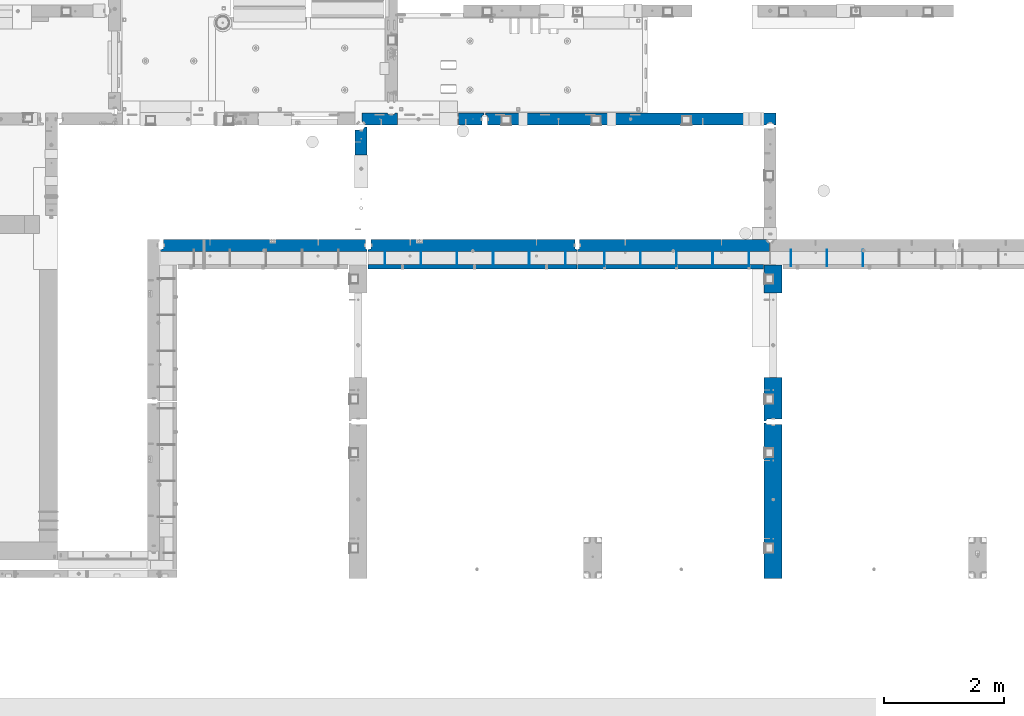
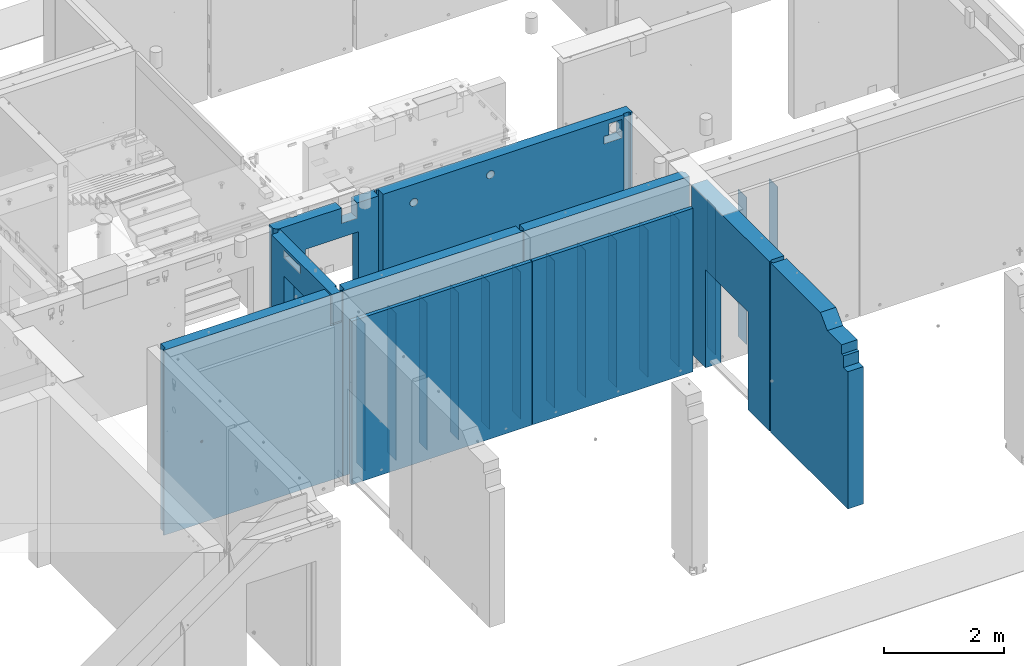
# One storey, part 172 of 264: 24 walls, 9 elements without a shape of their own.
"""IFC2X3 building model written with IfcOpenShell, lengths in millimetres."""

from ifc_helpers import new_model, si_unit, frame, origin_with_axes, place, context, subcontext, project, spatial, faceted_brep, material, type_object, element, aggregate, save


model = new_model("IFC2X3")

# Units and contexts
model_context = context("Model", 3, precision=1e-05, world=origin_with_axes())
body_context = subcontext(model_context, "Body", "Model", "MODEL_VIEW")
ifc_project = project(units=[si_unit("LENGTHUNIT", "METRE", prefix="MILLI"), si_unit("AREAUNIT", "SQUARE_METRE"), si_unit("VOLUMEUNIT", "CUBIC_METRE"), si_unit("MASSUNIT", "GRAM", prefix="KILO"), si_unit("TIMEUNIT", "SECOND"), si_unit("PLANEANGLEUNIT", "RADIAN"), si_unit("SOLIDANGLEUNIT", "STERADIAN"), si_unit("THERMODYNAMICTEMPERATUREUNIT", "DEGREE_CELSIUS"), si_unit("LUMINOUSINTENSITYUNIT", "LUMEN")], contexts=[model_context])

# Site, building, storey
site_placement = place(None, origin_with_axes())
site = spatial("IfcSite", under=ifc_project, at=site_placement, CompositionType="ELEMENT")
building_placement = place(site_placement, origin_with_axes())
building = spatial("IfcBuilding", under=site, at=building_placement, CompositionType="ELEMENT")
storey_placement = place(building_placement, origin_with_axes())
storey = spatial("IfcBuildingStorey", under=building, at=storey_placement, Name="K", CompositionType="ELEMENT", Elevation=0.0)

# Assembly, walls
assembly_1_placement = place(storey_placement, origin_with_axes())
assembly_1 = element("IfcElementAssembly", 1, at=assembly_1_placement, inside=storey, AssemblyPlace="NOTDEFINED", PredefinedType="REINFORCEMENT_UNIT")
ifc_material_1 = material(Name="Undefined")
wall_type_1 = type_object("IfcWallType", PredefinedType="NOTDEFINED")
wall_1_placement = place(assembly_1_placement, frame((25204.9962229193, 12730.0010506694, 79360.0), z_axis=(0.0, 0.0, 1.0), x_axis=(0.0, 1.0, 0.0)))
wall_1 = element("IfcWall", 2, at=wall_1_placement, type_object=wall_type_1, material=ifc_material_1, Name="(PD)", context=body_context, shape_type="Brep", body=[
    faceted_brep([(0.0, 4.99999999999909, -1500.0), (0.0, 4.99999999999909, 1500.0), (280.000000000024, 5.0, 1500.0), (280.000000000024, 5.0, -1500.0), (0.0, -5.00000000000091, 1500.0), (280.000000000025, -5.0, 1500.0), (0.0, -5.00000000000091, -1500.0), (280.000000000025, -5.0, -1500.0)], [[[0, 1, 2, 3]], [[1, 4, 5, 2]], [[4, 6, 7, 5]], [[6, 0, 3, 7]], [[5, 7, 3, 2]], [[6, 4, 1, 0]]]),
])
wall_2_placement = place(assembly_1_placement, frame((24604.9962229193, 12730.0010506694, 79360.0), z_axis=(0.0, 0.0, 1.0), x_axis=(0.0, 1.0, 0.0)))
wall_2 = element("IfcWall", 3, at=wall_2_placement, type_object=wall_type_1, material=ifc_material_1, Name="(PD)", context=body_context, shape_type="Brep", body=[
    faceted_brep([(0.0, 4.99999999999909, -1500.0), (0.0, 4.99999999999909, 1500.0), (280.000000000024, 5.0, 1500.0), (280.000000000024, 5.0, -1500.0), (0.0, -5.00000000000091, 1500.0), (280.000000000025, -5.0, 1500.0), (0.0, -5.00000000000091, -1500.0), (280.000000000025, -5.0, -1500.0)], [[[0, 1, 2, 3]], [[1, 4, 5, 2]], [[4, 6, 7, 5]], [[6, 0, 3, 7]], [[5, 7, 3, 2]], [[6, 4, 1, 0]]]),
])
wall_3_placement = place(assembly_1_placement, frame((24004.9962229193, 12730.0010506694, 79360.0), z_axis=(0.0, 0.0, 1.0), x_axis=(0.0, 1.0, 0.0)))
wall_3 = element("IfcWall", 4, at=wall_3_placement, type_object=wall_type_1, material=ifc_material_1, Name="(PD)", context=body_context, shape_type="Brep", body=[
    faceted_brep([(0.0, 4.99999999999909, -1500.0), (0.0, 4.99999999999909, 1500.0), (280.000000000024, 5.0, 1500.0), (280.000000000024, 5.0, -1500.0), (0.0, -5.00000000000091, 1500.0), (280.000000000025, -5.0, 1500.0), (0.0, -5.00000000000091, -1500.0), (280.000000000025, -5.0, -1500.0)], [[[0, 1, 2, 3]], [[1, 4, 5, 2]], [[4, 6, 7, 5]], [[6, 0, 3, 7]], [[5, 7, 3, 2]], [[6, 4, 1, 0]]]),
])
wall_4_placement = place(assembly_1_placement, frame((23404.9962229193, 12730.0010506694, 79360.0), z_axis=(0.0, 0.0, 1.0), x_axis=(0.0, 1.0, 0.0)))
wall_4 = element("IfcWall", 5, at=wall_4_placement, type_object=wall_type_1, material=ifc_material_1, Name="(PD)", context=body_context, shape_type="Brep", body=[
    faceted_brep([(0.0, 4.99999999999909, -1500.0), (0.0, 4.99999999999909, 1500.0), (280.000000000024, 5.0, 1500.0), (280.000000000024, 5.0, -1500.0), (0.0, -5.00000000000091, 1500.0), (280.000000000025, -5.0, 1500.0), (0.0, -5.00000000000091, -1500.0), (280.000000000025, -5.0, -1500.0)], [[[0, 1, 2, 3]], [[1, 4, 5, 2]], [[4, 6, 7, 5]], [[6, 0, 3, 7]], [[5, 7, 3, 2]], [[6, 4, 1, 0]]]),
])
wall_5_placement = place(assembly_1_placement, frame((22804.9962229193, 12730.0010506694, 79360.0), z_axis=(0.0, 0.0, 1.0), x_axis=(0.0, 1.0, 0.0)))
wall_5 = element("IfcWall", 6, at=wall_5_placement, type_object=wall_type_1, material=ifc_material_1, Name="(PD)", context=body_context, shape_type="Brep", body=[
    faceted_brep([(0.0, 4.99999999999909, -1500.0), (0.0, 4.99999999999909, 1500.0), (280.000000000024, 5.0, 1500.0), (280.000000000024, 5.0, -1500.0), (0.0, -5.00000000000091, 1500.0), (280.000000000025, -5.0, 1500.0), (0.0, -5.00000000000091, -1500.0), (280.000000000025, -5.0, -1500.0)], [[[0, 1, 2, 3]], [[1, 4, 5, 2]], [[4, 6, 7, 5]], [[6, 0, 3, 7]], [[5, 7, 3, 2]], [[6, 4, 1, 0]]]),
])

# Assembly, wall
assembly_2_placement = place(storey_placement, origin_with_axes())
assembly_2 = element("IfcElementAssembly", 7, at=assembly_2_placement, inside=storey, AssemblyPlace="NOTDEFINED", PredefinedType="REINFORCEMENT_UNIT")
wall_6_placement = place(assembly_2_placement, frame((28254.9962229193, 12730.0010506694, 79360.0), z_axis=(0.0, 0.0, 1.0), x_axis=(0.0, 1.0, 0.0)))
wall_6 = element("IfcWall", 8, at=wall_6_placement, type_object=wall_type_1, material=ifc_material_1, Name="(PD)", context=body_context, shape_type="Brep", body=[
    faceted_brep([(0.0, 4.99999999999909, -1500.0), (0.0, 4.99999999999909, 1500.0), (280.000000000024, 5.0, 1500.0), (280.000000000024, 5.0, -1500.0), (0.0, -5.00000000000091, 1500.0), (280.000000000025, -5.0, 1500.0), (0.0, -5.00000000000091, -1500.0), (280.000000000025, -5.0, -1500.0)], [[[0, 1, 2, 3]], [[1, 4, 5, 2]], [[4, 6, 7, 5]], [[6, 0, 3, 7]], [[5, 7, 3, 2]], [[6, 4, 1, 0]]]),
])

# Wall
wall_7_placement = place(assembly_1_placement, frame((22204.9962229193, 12730.0010506694, 79360.0), z_axis=(0.0, 0.0, 1.0), x_axis=(0.0, 1.0, 0.0)))
wall_7 = element("IfcWall", 9, at=wall_7_placement, type_object=wall_type_1, material=ifc_material_1, Name="(PD)", context=body_context, shape_type="Brep", body=[
    faceted_brep([(0.0, 4.99999999999909, -1500.0), (0.0, 4.99999999999909, 1500.0), (280.000000000024, 5.0, 1500.0), (280.000000000024, 5.0, -1500.0), (0.0, -5.00000000000091, 1500.0), (280.000000000025, -5.0, 1500.0), (0.0, -5.00000000000091, -1500.0), (280.000000000025, -5.0, -1500.0)], [[[0, 1, 2, 3]], [[1, 4, 5, 2]], [[4, 6, 7, 5]], [[6, 0, 3, 7]], [[5, 7, 3, 2]], [[6, 4, 1, 0]]]),
])

wall_8_placement = place(assembly_2_placement, frame((25854.9962229193, 12730.0010506694, 79360.0), z_axis=(0.0, 0.0, 1.0), x_axis=(0.0, 1.0, 0.0)))
wall_8 = element("IfcWall", 10, at=wall_8_placement, type_object=wall_type_1, material=ifc_material_1, Name="(PD)", context=body_context, shape_type="Brep", body=[
    faceted_brep([(0.0, 4.99999999999909, -1500.0), (0.0, 4.99999999999909, 1500.0), (280.000000000024, 5.0, 1500.0), (280.000000000024, 5.0, -1500.0), (0.0, -5.00000000000091, 1500.0), (280.000000000025, -5.0, 1500.0), (0.0, -5.00000000000091, -1500.0), (280.000000000025, -5.0, -1500.0)], [[[0, 1, 2, 3]], [[1, 4, 5, 2]], [[4, 6, 7, 5]], [[6, 0, 3, 7]], [[5, 7, 3, 2]], [[6, 4, 1, 0]]]),
])

wall_9_placement = place(assembly_2_placement, frame((26454.9962229193, 12730.0010506694, 79360.0), z_axis=(0.0, 0.0, 1.0), x_axis=(0.0, 1.0, 0.0)))
wall_9 = element("IfcWall", 11, at=wall_9_placement, type_object=wall_type_1, material=ifc_material_1, Name="(PD)", context=body_context, shape_type="Brep", body=[
    faceted_brep([(0.0, 4.99999999999909, -1500.0), (0.0, 4.99999999999909, 1500.0), (280.000000000024, 5.0, 1500.0), (280.000000000024, 5.0, -1500.0), (0.0, -5.00000000000091, 1500.0), (280.000000000025, -5.0, 1500.0), (0.0, -5.00000000000091, -1500.0), (280.000000000025, -5.0, -1500.0)], [[[0, 1, 2, 3]], [[1, 4, 5, 2]], [[4, 6, 7, 5]], [[6, 0, 3, 7]], [[5, 7, 3, 2]], [[6, 4, 1, 0]]]),
])

wall_10_placement = place(assembly_2_placement, frame((27054.9962229193, 12730.0010506694, 79360.0), z_axis=(0.0, 0.0, 1.0), x_axis=(0.0, 1.0, 0.0)))
wall_10 = element("IfcWall", 12, at=wall_10_placement, type_object=wall_type_1, material=ifc_material_1, Name="(PD)", context=body_context, shape_type="Brep", body=[
    faceted_brep([(0.0, 4.99999999999909, -1500.0), (0.0, 4.99999999999909, 1500.0), (280.000000000024, 5.0, 1500.0), (280.000000000024, 5.0, -1500.0), (0.0, -5.00000000000091, 1500.0), (280.000000000025, -5.0, 1500.0), (0.0, -5.00000000000091, -1500.0), (280.000000000025, -5.0, -1500.0)], [[[0, 1, 2, 3]], [[1, 4, 5, 2]], [[4, 6, 7, 5]], [[6, 0, 3, 7]], [[5, 7, 3, 2]], [[6, 4, 1, 0]]]),
])

wall_11_placement = place(assembly_2_placement, frame((27654.9962229193, 12730.0010506694, 79360.0), z_axis=(0.0, 0.0, 1.0), x_axis=(0.0, 1.0, 0.0)))
wall_11 = element("IfcWall", 13, at=wall_11_placement, type_object=wall_type_1, material=ifc_material_1, Name="(PD)", context=body_context, shape_type="Brep", body=[
    faceted_brep([(0.0, 4.99999999999909, -1500.0), (0.0, 4.99999999999909, 1500.0), (280.000000000024, 5.0, 1500.0), (280.000000000024, 5.0, -1500.0), (0.0, -5.00000000000091, 1500.0), (280.000000000025, -5.0, 1500.0), (0.0, -5.00000000000091, -1500.0), (280.000000000025, -5.0, -1500.0)], [[[0, 1, 2, 3]], [[1, 4, 5, 2]], [[4, 6, 7, 5]], [[6, 0, 3, 7]], [[5, 7, 3, 2]], [[6, 4, 1, 0]]]),
])

# Assembly, walls
assembly_3_placement = place(storey_placement, origin_with_axes())
assembly_3 = element("IfcElementAssembly", 14, at=assembly_3_placement, inside=storey, AssemblyPlace="NOTDEFINED", PredefinedType="REINFORCEMENT_UNIT")
wall_12_placement = place(assembly_3_placement, frame((28955.0062229193, 12730.0010506694, 79360.0), z_axis=(0.0, 0.0, 1.0), x_axis=(0.0, 1.0, 0.0)))
wall_12 = element("IfcWall", 15, at=wall_12_placement, type_object=wall_type_1, material=ifc_material_1, Name="(PD)", context=body_context, shape_type="Brep", body=[
    faceted_brep([(0.0, 4.99999999999909, -1500.0), (0.0, 4.99999999999909, 1500.0), (280.000000000024, 5.0, 1500.0), (280.000000000024, 5.0, -1500.0), (0.0, -5.00000000000091, 1500.0), (280.000000000025, -5.0, 1500.0), (0.0, -5.00000000000091, -1500.0), (280.000000000025, -5.0, -1500.0)], [[[0, 1, 2, 3]], [[1, 4, 5, 2]], [[4, 6, 7, 5]], [[6, 0, 3, 7]], [[5, 7, 3, 2]], [[6, 4, 1, 0]]]),
])
wall_13_placement = place(assembly_3_placement, frame((29555.0062229193, 12730.0010506694, 79360.0), z_axis=(0.0, 0.0, 1.0), x_axis=(0.0, 1.0, 0.0)))
wall_13 = element("IfcWall", 16, at=wall_13_placement, type_object=wall_type_1, material=ifc_material_1, Name="(PD)", context=body_context, shape_type="Brep", body=[
    faceted_brep([(0.0, 4.99999999999909, -1500.0), (0.0, 4.99999999999909, 1500.0), (280.000000000024, 5.0, 1500.0), (280.000000000024, 5.0, -1500.0), (0.0, -5.00000000000091, 1500.0), (280.000000000025, -5.0, 1500.0), (0.0, -5.00000000000091, -1500.0), (280.000000000025, -5.0, -1500.0)], [[[0, 1, 2, 3]], [[1, 4, 5, 2]], [[4, 6, 7, 5]], [[6, 0, 3, 7]], [[5, 7, 3, 2]], [[6, 4, 1, 0]]]),
])
wall_14_placement = place(assembly_3_placement, frame((30155.0062229193, 12730.0010506694, 79360.0), z_axis=(0.0, 0.0, 1.0), x_axis=(0.0, 1.0, 0.0)))
wall_14 = element("IfcWall", 17, at=wall_14_placement, type_object=wall_type_1, material=ifc_material_1, Name="(PD)", context=body_context, shape_type="Brep", body=[
    faceted_brep([(0.0, 4.99999999999909, -1500.0), (0.0, 4.99999999999909, 1500.0), (280.000000000024, 5.0, 1500.0), (280.000000000024, 5.0, -1500.0), (0.0, -5.00000000000091, 1500.0), (280.000000000025, -5.0, 1500.0), (0.0, -5.00000000000091, -1500.0), (280.000000000025, -5.0, -1500.0)], [[[0, 1, 2, 3]], [[1, 4, 5, 2]], [[4, 6, 7, 5]], [[6, 0, 3, 7]], [[5, 7, 3, 2]], [[6, 4, 1, 0]]]),
])
aggregate(assembly_3, [wall_12, wall_13, wall_14])

# Assembly, wall
assembly_4_placement = place(storey_placement, origin_with_axes())
assembly_4 = element("IfcElementAssembly", 18, at=assembly_4_placement, inside=storey, AssemblyPlace="NOTDEFINED", PredefinedType="REINFORCEMENT_UNIT")
ifc_material_2 = material(Name="CONCRETE/C30/37")
wall_type_2 = type_object("IfcWallType", PredefinedType="NOTDEFINED")
wall_15_placement = place(assembly_4_placement, frame((28660.0, 10145.0, 79745.0), z_axis=(0.0, 0.0, 1.0), x_axis=(0.0, 1.0, 0.0)))
wall_15 = element("IfcWall", 19, at=wall_15_placement, type_object=wall_type_2, material=ifc_material_2, context=body_context, shape_type="Brep", body=[
    faceted_brep([(15.0, 120.0, 1725.0), (15.0, 120.0, -1725.0), (45.0, 107.0, -1725.0), (45.0, 107.0, 1725.0), (45.0, -150.0, 1725.0), (45.0, -150.0, -1725.0), (734.999769628048, -150.0, -1725.0), (734.999769628048, 150.0, -1725.0), (734.999769628048, 150.000154078007, 270.0), (734.999769628048, -150.0, 270.0), (2610.0, 150.0, -1725.0), (2610.0, -150.0, -1725.0), (2145.00189658492, -150.0, -1725.0), (2145.00189658492, 150.0, -1725.0), (2145.00189658492, -150.0, 270.0), (2145.00189658492, 150.000154078007, 270.0), (15.0, 150.0, -1725.0), (15.0, 150.0, 1725.0), (2610.0, 150.0, 1725.0), (2610.0, -150.0, 1725.0)], [[[0, 1, 2, 3]], [[4, 3, 2, 5]], [[6, 7, 8, 9]], [[10, 11, 12, 13]], [[14, 15, 13, 12]], [[9, 8, 15, 14]], [[7, 16, 17, 18, 10, 13, 15, 8]], [[19, 11, 10, 18]], [[6, 9, 14, 12, 11, 19, 4, 5]], [[1, 16, 7, 6, 5, 2]], [[17, 16, 1, 0]], [[19, 18, 17, 0, 3, 4]]]),
])
aggregate(assembly_4, [wall_15])

assembly_5_placement = place(storey_placement, origin_with_axes())
assembly_5 = element("IfcElementAssembly", 20, at=assembly_5_placement, inside=storey, AssemblyPlace="NOTDEFINED", PredefinedType="REINFORCEMENT_UNIT")
wall_16_placement = place(assembly_5_placement, frame((28660.0, 7545.0, 79745.0), z_axis=(0.0, 0.0, 1.0), x_axis=(0.0, 1.0, 0.0)))
wall_16 = element("IfcWall", 21, at=wall_16_placement, type_object=wall_type_2, material=ifc_material_2, context=body_context, shape_type="Brep", body=[
    faceted_brep([(145.0, -150.0, 1070.0), (145.0, 150.0, 1070.0), (0.0, 150.0, 1070.0), (0.0, -150.0, 1070.0), (145.0, -150.0, 1305.0), (145.0, 150.0, 1305.0), (0.0, -150.0, -1725.0), (0.0, 150.0, -1725.0), (2585.0, 150.0, -1725.0), (2585.0, 119.999999999996, -1725.0), (2555.0, 107.0, -1725.0), (2555.0, -150.0, -1725.0), (2585.0, 150.0, 1725.0), (2585.0, 119.999999999996, 1725.0), (2555.0, 107.0, 1725.0), (2555.0, -150.0, 1725.0), (914.999832520542, 150.0, 1725.0), (914.999832520542, -150.0, 1725.0), (684.999832520542, 150.0, 1495.0), (684.999832520542, -150.0, 1495.0), (205.0, 150.0, 1495.0), (205.0, -150.0, 1495.0), (205.0, 150.0, 1305.0), (205.0, -150.0, 1305.0)], [[[0, 1, 2, 3]], [[4, 5, 1, 0]], [[6, 7, 8, 9, 10, 11]], [[8, 12, 13, 9]], [[14, 10, 9, 13]], [[15, 11, 10, 14]], [[13, 12, 16, 17, 15, 14]], [[17, 16, 18, 19]], [[19, 18, 20, 21]], [[21, 20, 22, 23]], [[3, 6, 11, 15, 17, 19, 21, 23, 4, 0]], [[7, 6, 3, 2]], [[22, 20, 18, 16, 12, 8, 7, 2, 1, 5]], [[23, 22, 5, 4]]]),
])
aggregate(assembly_5, [wall_16])

# Wall
wall_type_3 = type_object("IfcWallType", PredefinedType="NOTDEFINED")
wall_17_placement = place(assembly_1_placement, frame((25395.0012286569, 12725.0018965848, 79365.0), z_axis=(0.0, 0.0, 1.0), x_axis=(-1.0, 3.00000001838171e-08, 0.0)))
wall_17 = element("IfcWall", 22, at=wall_17_placement, type_object=wall_type_3, material=ifc_material_2, context=body_context, shape_type="Brep", body=[
    faceted_brep([(0.0, 35.0, -1665.0), (0.0, 35.0, 1665.0), (3470.00122865687, 35.0, 1665.0), (3470.00122865687, 35.0, -1665.0), (0.0, -35.0, 1665.0), (3470.00122865687, -35.0, 1665.0), (0.0, -35.0, -1665.0), (3470.00122865687, -35.0, -1665.0)], [[[0, 1, 2, 3]], [[1, 4, 5, 2]], [[4, 6, 7, 5]], [[6, 0, 3, 7]], [[5, 7, 3, 2]], [[6, 4, 1, 0]]]),
])

wall_18_placement = place(assembly_2_placement, frame((28495.0, 12725.0018965848, 79365.0), z_axis=(0.0, 0.0, 1.0), x_axis=(-1.0, 3.00000001838171e-08, 0.0)))
wall_18 = element("IfcWall", 23, at=wall_18_placement, type_object=wall_type_3, material=ifc_material_2, context=body_context, shape_type="Brep", body=[
    faceted_brep([(0.0, 35.0, -1665.0), (0.0, 35.0, 1665.0), (3085.0, 35.0, 1665.0), (3085.0, 35.0, -1665.0), (0.0, -35.0, 1665.0), (3085.0, -35.0, 1665.0), (0.0, -35.0, -1665.0), (3085.0, -35.0, -1665.0)], [[[0, 1, 2, 3]], [[1, 4, 5, 2]], [[4, 6, 7, 5]], [[6, 0, 3, 7]], [[5, 7, 3, 2]], [[6, 4, 1, 0]]]),
])

# Assembly, wall
assembly_6_placement = place(storey_placement, origin_with_axes())
assembly_6 = element("IfcElementAssembly", 24, at=assembly_6_placement, inside=storey, AssemblyPlace="NOTDEFINED", PredefinedType="REINFORCEMENT_UNIT")
ifc_material_3 = material(Name="CONCRETE/C25/30")
wall_type_4 = type_object("IfcWallType", PredefinedType="NOTDEFINED")
wall_19_placement = place(assembly_6_placement, frame((21810.0002919986, 15180.0, 80122.5), z_axis=(0.0, 0.0, 1.0), x_axis=(1.0, 0.0, 0.0)))
wall_19 = element("IfcWall", 25, at=wall_19_placement, type_object=wall_type_4, material=ifc_material_3, context=body_context, shape_type="Brep", body=[
    faceted_brep([(1599.9997446583, 100.0, 1347.5), (1599.9997446583, 99.9999999999964, 1337.5), (1599.9997446583, -99.9999999999982, 1337.5), (1599.9997446583, -100.0, 1347.5), (1299.9997446583, 100.0, 1347.5), (1299.9997446583, -100.0, 1347.5), (1299.9997446583, -99.9999999999982, 1337.5), (1299.9997446583, 99.9999999999964, 1337.5), (2039.99985400072, 100.0, -1347.5), (2039.99985400072, 100.0, 1347.5), (2039.99985400072, 70.0, 1347.5), (2039.99985400072, 70.0, -1347.5), (2009.99985400072, -100.0, 1347.5), (2009.99985400072, 57.0, 1347.5), (2009.99985400072, -100.0, -1347.5), (2009.99985400072, 57.0, -1347.5), (1619.99614120679, -100.0, -1347.5), (1619.99667220679, 100.0, -1347.5), (1619.99614120679, -100.0, 752.5), (1619.99667220678, 100.0, 752.5), (599.99917704994, -100.0, 752.5), (599.999708049942, 100.0, 752.5), (599.99917704994, -100.0, -1347.5), (599.999708049942, 100.0, -1347.5), (74.9997080014437, -100.0, -1347.5), (14.9997080014437, -40.0, -1347.5), (14.9997080014437, 100.0, -1347.5), (434.999708001444, 100.0, -1347.5), (447.999708001444, 80.0, -1347.5), (551.999708001444, 80.0, -1347.5), (564.999708001447, 100.0, -1347.5), (74.9997080014437, -100.0, 1347.5), (14.9997080014437, -40.0, 1347.5), (14.9997080014437, 100.0, 1347.5), (434.999708001444, 100.0, 1347.5), (447.999708001444, 80.0, 1347.5), (551.999708001444, 80.0, 1347.5), (564.999708001444, 100.0, 1347.5), (1299.9997446583, -99.9999999999982, 1037.5), (1299.9997446583, 99.9999999999964, 1037.5), (1599.9997446583, -99.9999999999982, 1037.5), (1599.9997446583, 99.9999999999964, 1037.5)], [[[0, 1, 2, 3]], [[4, 5, 6, 7]], [[8, 9, 10, 11]], [[12, 13, 10, 9, 0, 3]], [[12, 14, 15, 13]], [[10, 13, 15, 11]], [[14, 16, 17, 8, 11, 15]], [[17, 16, 18, 19]], [[19, 18, 20, 21]], [[21, 20, 22, 23]], [[23, 22, 24, 25, 26, 27, 28, 29, 30]], [[31, 32, 25, 24]], [[33, 26, 25, 32]], [[26, 33, 34, 27]], [[35, 28, 27, 34]], [[36, 29, 28, 35]], [[37, 30, 29, 36]], [[7, 6, 38, 39]], [[39, 38, 40, 41]], [[41, 40, 2, 1]], [[9, 8, 17, 19, 21, 23, 30, 37, 4, 7, 39, 41, 1, 0]], [[40, 38, 6, 5, 31, 24, 22, 20, 18, 16, 14, 12, 3, 2]], [[37, 36, 35, 34, 33, 32, 31, 5, 4]]]),
])
aggregate(assembly_6, [wall_19])

assembly_7_placement = place(storey_placement, origin_with_axes())
assembly_7 = element("IfcElementAssembly", 26, at=assembly_7_placement, inside=storey, AssemblyPlace="NOTDEFINED", PredefinedType="REINFORCEMENT_UNIT")
wall_20_placement = place(assembly_7_placement, frame((23850.0002919986, 15180.0, 80122.5), z_axis=(0.0, 0.0, 1.0), x_axis=(1.0, 0.0, 0.0)))
wall_20 = element("IfcWall", 27, at=wall_20_placement, type_object=wall_type_4, material=ifc_material_3, context=body_context, shape_type="Brep", body=[
    faceted_brep([(4409.99955392195, 100.0, 1262.49638124536), (4409.99955392195, -100.0, 1262.49638124536), (4409.9995539208, -100.0, 1037.5), (4409.9995539208, 100.0, 1037.5), (4659.99955392195, 100.0, 1262.49999998933), (4659.99955392195, -100.0, 1262.49999998933), (4659.99955392344, 100.0, 1037.5), (4659.99955392344, -100.0, 1037.5), (4694.99970800144, -100.0, 1347.5), (4694.99970800144, -100.0, -1347.5), (4707.99970800144, -70.0, -1347.5), (4707.99970800144, -70.0, 1347.5), (4811.99970800144, -70.0, -1347.5), (4811.99970800144, -70.0, 1347.5), (4824.99970800144, -100.0, 1347.5), (4824.99970800144, -100.0, -1347.5), (4859.99970800144, -100.0, -1347.5), (4859.99970800144, -100.0, 1347.5), (4859.99970800144, 100.0, -1347.5), (4859.99970800144, 100.0, 1347.5), (29.9998715127422, 100.0, 1347.5), (29.9998715127422, 70.0, 1347.5), (59.9998540007218, 57.0, 1347.5), (59.9998540007218, -100.0, 1347.5), (29.9998715127422, 100.0, -1347.5), (29.9998715127422, 70.0, -1347.5), (59.9998540007218, 57.0, -1347.5), (59.9998540007218, -100.0, -1347.5), (714.952299930785, 100.0, 940.0), (714.952299930785, -100.0, 940.0), (722.444831618632, -100.0, 958.088571617307), (722.444831618632, 100.0, 958.088571617307), (703.033403235942, 100.0, 924.466991411013), (703.033403235942, -100.0, 924.466991411013), (687.500394646951, 100.0, 912.54809471617), (687.500394646951, -100.0, 912.54809471617), (669.411823029641, 100.0, 905.05556302832), (669.411823029641, -100.0, 905.05556302832), (650.000394646951, 100.0, 902.5), (650.000394646951, -100.0, 902.5), (630.588966264262, 100.0, 905.05556302832), (630.588966264262, -100.0, 905.05556302832), (612.500394646951, 100.0, 912.54809471617), (612.500394646951, -100.0, 912.54809471617), (596.967386057961, 100.0, 924.466991411013), (596.967386057961, -100.0, 924.466991411013), (585.048489363118, 100.0, 940.0), (585.048489363118, -100.0, 940.0), (577.555957675271, 100.0, 958.088571617307), (577.555957675271, -100.0, 958.088571617307), (575.000394646951, 100.0, 977.5), (575.000394646951, -100.0, 977.5), (577.555957675271, 100.0, 996.911428382693), (577.555957675271, -100.0, 996.911428382693), (585.048489363118, 100.0, 1015.0), (585.048489363118, -100.0, 1015.0), (596.967386057961, 100.0, 1030.53300858899), (596.967386057961, -100.0, 1030.53300858899), (612.500394646951, 100.0, 1042.45190528383), (612.500394646951, -100.0, 1042.45190528383), (630.588966264262, 100.0, 1049.94443697168), (630.588966264262, -100.0, 1049.94443697168), (650.000394646951, 100.0, 1052.5), (650.000394646951, -100.0, 1052.5), (669.411823029641, 100.0, 1049.94443697168), (669.411823029641, -100.0, 1049.94443697168), (687.500394646951, 100.0, 1042.45190528383), (687.500394646951, -100.0, 1042.45190528383), (703.033403235942, 100.0, 1030.53300858899), (703.033403235942, -100.0, 1030.53300858899), (714.952299930785, 100.0, 1015.0), (714.952299930785, -100.0, 1015.0), (722.444831618632, 100.0, 996.911428382693), (722.444831618632, -100.0, 996.911428382693), (725.000394646951, 100.0, 977.5), (725.000394646951, -100.0, 977.5), (2190.00761155102, 100.0, 990.0), (2190.00761155102, -100.0, 990.0), (2197.50014323887, -100.0, 1008.08857161731), (2197.50014323887, 100.0, 1008.08857161731), (2178.08871485618, 100.0, 974.466991411013), (2178.08871485618, -100.0, 974.466991411013), (2162.55570626719, 100.0, 962.54809471617), (2162.55570626719, -100.0, 962.54809471617), (2144.46713464988, 100.0, 955.05556302832), (2144.46713464988, -100.0, 955.05556302832), (2125.05570626719, 100.0, 952.5), (2125.05570626719, -100.0, 952.5), (2105.6442778845, 100.0, 955.05556302832), (2105.6442778845, -100.0, 955.05556302832), (2087.55570626719, 100.0, 962.54809471617), (2087.55570626719, -100.0, 962.54809471617), (2072.0226976782, 100.0, 974.466991411013), (2072.0226976782, -100.0, 974.466991411013), (2060.10380098335, 100.0, 990.0), (2060.10380098335, -100.0, 990.0), (2052.61126929551, 100.0, 1008.08857161731), (2052.61126929551, -100.0, 1008.08857161731), (2050.05570626719, 100.0, 1027.5), (2050.05570626719, -100.0, 1027.5), (2052.61126929551, 100.0, 1046.91142838269), (2052.61126929551, -100.0, 1046.91142838269), (2060.10380098335, 100.0, 1065.0), (2060.10380098335, -100.0, 1065.0), (2072.0226976782, 100.0, 1080.53300858899), (2072.0226976782, -100.0, 1080.53300858899), (2087.55570626719, 100.0, 1092.45190528383), (2087.55570626719, -100.0, 1092.45190528383), (2105.6442778845, 100.0, 1099.94443697168), (2105.6442778845, -100.0, 1099.94443697168), (2125.05570626719, 100.0, 1102.5), (2125.05570626719, -100.0, 1102.5), (2144.46713464988, 100.0, 1099.94443697168), (2144.46713464988, -100.0, 1099.94443697168), (2162.55570626719, 100.0, 1092.45190528383), (2162.55570626719, -100.0, 1092.45190528383), (2178.08871485618, 100.0, 1080.53300858899), (2178.08871485618, -100.0, 1080.53300858899), (2190.00761155102, 100.0, 1065.0), (2190.00761155102, -100.0, 1065.0), (2197.50014323887, 100.0, 1046.91142838269), (2197.50014323887, -100.0, 1046.91142838269), (2200.05570626719, 100.0, 1027.5), (2200.05570626719, -100.0, 1027.5), (4309.99955392344, 100.0, 887.5), (4309.99955392344, -100.0, 887.5), (4659.99955392344, -100.0, 887.5), (4659.99955392344, 100.0, 887.5), (4309.99955392344, 100.0, 1037.5), (4309.99955392344, -100.0, 1037.5), (4659.99955392344, -100.0, 1007.50001283716), (4659.99955392344, 100.0, 1007.50001283716)], [[[0, 1, 2, 3]], [[4, 5, 1, 0]], [[6, 7, 5, 4]], [[8, 9, 10, 11]], [[11, 10, 12, 13]], [[14, 13, 12, 15]], [[16, 17, 14, 15]], [[17, 16, 18, 19]], [[8, 11, 13, 14, 17, 19, 20, 21, 22, 23]], [[20, 24, 25, 21]], [[21, 25, 26, 22]], [[24, 18, 16, 15, 12, 10, 9, 27, 26, 25]], [[22, 26, 27, 23]], [[28, 29, 30, 31]], [[32, 33, 29, 28]], [[34, 35, 33, 32]], [[36, 37, 35, 34]], [[38, 39, 37, 36]], [[40, 41, 39, 38]], [[42, 43, 41, 40]], [[44, 45, 43, 42]], [[46, 47, 45, 44]], [[48, 49, 47, 46]], [[50, 51, 49, 48]], [[52, 53, 51, 50]], [[54, 55, 53, 52]], [[56, 57, 55, 54]], [[58, 59, 57, 56]], [[60, 61, 59, 58]], [[62, 63, 61, 60]], [[64, 65, 63, 62]], [[66, 67, 65, 64]], [[68, 69, 67, 66]], [[70, 71, 69, 68]], [[72, 73, 71, 70]], [[74, 75, 73, 72]], [[31, 30, 75, 74]], [[76, 77, 78, 79]], [[80, 81, 77, 76]], [[82, 83, 81, 80]], [[84, 85, 83, 82]], [[86, 87, 85, 84]], [[88, 89, 87, 86]], [[90, 91, 89, 88]], [[92, 93, 91, 90]], [[94, 95, 93, 92]], [[96, 97, 95, 94]], [[98, 99, 97, 96]], [[100, 101, 99, 98]], [[102, 103, 101, 100]], [[104, 105, 103, 102]], [[106, 107, 105, 104]], [[108, 109, 107, 106]], [[110, 111, 109, 108]], [[112, 113, 111, 110]], [[114, 115, 113, 112]], [[116, 117, 115, 114]], [[118, 119, 117, 116]], [[120, 121, 119, 118]], [[122, 123, 121, 120]], [[79, 78, 123, 122]], [[124, 125, 126, 127]], [[128, 129, 125, 124]], [[129, 128, 3, 2]], [[9, 8, 23, 27], [130, 126, 125, 129, 2, 1, 5, 7], [77, 81, 83, 85, 87, 89, 91, 93, 95, 97, 99, 101, 103, 105, 107, 109, 111, 113, 115, 117, 119, 121, 123, 78], [29, 33, 35, 37, 39, 41, 43, 45, 47, 49, 51, 53, 55, 57, 59, 61, 63, 65, 67, 69, 71, 73, 75, 30]], [[131, 127, 126, 130, 7, 6]], [[24, 20, 19, 18], [3, 128, 124, 127, 131, 6, 4, 0], [118, 116, 114, 112, 110, 108, 106, 104, 102, 100, 98, 96, 94, 92, 90, 88, 86, 84, 82, 80, 76, 79, 122, 120], [70, 68, 66, 64, 62, 60, 58, 56, 54, 52, 50, 48, 46, 44, 42, 40, 38, 36, 34, 32, 28, 31, 74, 72]]]),
])
aggregate(assembly_7, [wall_20])

assembly_8_placement = place(storey_placement, origin_with_axes())
assembly_8 = element("IfcElementAssembly", 28, at=assembly_8_placement, inside=storey, AssemblyPlace="NOTDEFINED", PredefinedType="REINFORCEMENT_UNIT")
wall_21_placement = place(assembly_8_placement, frame((21810.0, 12985.0, 80122.5), z_axis=(0.0, 0.0, 1.0), x_axis=(0.0, 1.0, 0.0)))
wall_21 = element("IfcWall", 29, at=wall_21_placement, type_object=wall_type_4, material=ifc_material_2, context=body_context, shape_type="Brep", body=[
    faceted_brep([(25.0018965847667, -100.0, 1347.5), (25.0018965847667, -100.0, 752.5), (38.0018961299265, -70.0012297441936, 752.5), (38.0018961299265, -70.0012297441936, 1347.5), (182.001892106136, -70.0012288768776, 752.5), (182.001892106136, -70.0012288768776, 1347.5), (195.001893023862, -100.002452403714, 1347.5), (195.001893023862, -100.0, 752.5), (0.0, -100.0, 1347.5), (0.0, 100.0, 1347.5), (0.0, 100.0, 752.5), (0.0, -100.0, 752.5), (1600.00037070586, -100.0, 752.5), (1600.00037070586, 100.0, 752.5), (1600.00037070586, 100.0, -1347.5), (1600.00037070586, -100.0, -1347.5), (2065.0, -100.0, 1347.5), (2065.0, -100.0, -1347.5), (2065.0, -60.0, -1347.5), (2065.0, -60.0, 1347.5), (2015.0, -30.0, -1347.5), (2015.0, -30.0, 1347.5), (2015.0, 100.0, -1347.5), (2015.0, 100.0, 1347.5), (1044.99963611364, 100.0, 1137.5), (1594.99963611364, 100.0, 1137.5), (1594.99963611364, 100.0, 1287.5), (1044.99963611364, 100.0, 1287.5), (1044.99963611364, -100.0, 1287.5), (1594.99963611364, -100.0, 1287.5), (1044.99963611364, -100.0, 1137.5), (1594.99963611364, -100.0, 1137.5)], [[[0, 1, 2, 3]], [[3, 2, 4, 5]], [[6, 5, 4, 7]], [[8, 9, 10, 11]], [[12, 13, 14, 15]], [[16, 17, 18, 19]], [[19, 18, 20, 21]], [[17, 15, 14, 22, 20, 18]], [[21, 20, 22, 23]], [[14, 13, 10, 9, 23, 22], [24, 25, 26, 27]], [[28, 27, 26, 29]], [[30, 24, 27, 28]], [[31, 25, 24, 30]], [[29, 26, 25, 31]], [[12, 15, 17, 16, 6, 7], [30, 28, 29, 31]], [[2, 1, 11, 10, 13, 12, 7, 4]], [[8, 11, 1, 0]], [[16, 19, 21, 23, 9, 8, 0, 3, 5, 6]]]),
])
aggregate(assembly_8, [wall_21])

assembly_9_placement = place(storey_placement, origin_with_axes())
assembly_9 = element("IfcElementAssembly", 30, at=assembly_9_placement, inside=storey, AssemblyPlace="NOTDEFINED", PredefinedType="REINFORCEMENT_UNIT")
wall_type_5 = type_object("IfcWallType", PredefinedType="NOTDEFINED")
wall_22_placement = place(assembly_9_placement, frame((21910.0024573137, 13080.0018965848, 79585.0), z_axis=(0.0, 0.0, 1.0), x_axis=(-1.0, 3.00000001838171e-08, 0.0)))
wall_22 = element("IfcWall", 31, at=wall_22_placement, type_object=wall_type_5, material=ifc_material_3, context=body_context, shape_type="Brep", body=[
    faceted_brep([(2686.46143972936, -100.000000000002, -215.432914190867), (2686.46143972936, 99.9999999999982, -215.432914190867), (2691.88075851248, 99.9999999999982, -207.322330470342), (2691.88075851248, -100.000000000002, -207.322330470342), (2699.99134223302, 99.9999999999982, -201.903011687216), (2699.99134223302, -100.000000000002, -201.903011687216), (2709.55842804215, 99.9999999999982, -200.0), (2709.55842804215, -100.000000000002, -200.0), (2719.12551385128, 99.9999999999982, -201.903011687216), (2719.12551385128, -100.000000000002, -201.903011687216), (2727.23609757181, 99.9999999999982, -207.322330470342), (2727.23609757181, -100.000000000002, -207.322330470342), (2732.65541635493, 99.9999999999982, -215.432914190867), (2732.65541635493, -100.000000000002, -215.432914190867), (2734.55842804215, 99.9999999999982, -225.0), (2734.55842804215, -100.000000000002, -225.0), (2732.65541635493, 99.9999999999982, -234.567085809133), (2732.65541635493, -100.000000000002, -234.567085809133), (2727.23609757181, 99.9999999999982, -242.677669529658), (2727.23609757181, -100.000000000002, -242.677669529658), (2719.12551385128, 99.9999999999982, -248.096988312784), (2719.12551385128, -100.000000000002, -248.096988312784), (2709.55842804215, 99.9999999999982, -250.0), (2709.55842804215, -100.000000000002, -250.0), (2699.99134223302, 99.9999999999982, -248.096988312784), (2699.99134223302, -100.000000000002, -248.096988312784), (2691.88075851248, 99.9999999999982, -242.677669529658), (2691.88075851248, -100.000000000002, -242.677669529658), (2686.46143972936, 99.9999999999982, -234.567085809133), (2686.46143972936, -100.000000000002, -234.567085809133), (2684.55842804215, 99.9999999999982, -225.0), (2684.55842804215, -100.000000000002, -225.0), (0.00122865687444573, 100.0, -1885.0), (0.00122865687444573, 69.9999999999982, -1885.0), (0.00245731374889147, 69.9999999999982, 1265.0), (0.00122865687444573, 100.0, 1265.0), (3385.00245731375, -100.0, 1885.0), (3385.00245731375, -100.0, -1885.0), (3385.00245731375, 57.0, -1885.0), (3385.00245731375, 57.0, 1885.0), (30.0012286568744, -100.0, -1885.0), (225.00000064871, -100.0, 1885.0), (225.002457313749, -100.0, 1265.0), (30.0012286568744, -100.0, 1265.0), (30.0012286568744, 57.0, -1885.0), (30.0012286568744, 57.0, 1265.0), (3435.00245731375, 100.0, -1885.0), (3435.00245731375, 70.0, -1885.0), (3435.00245731375, 70.0, 1885.0), (3435.00245731375, 100.0, 1885.0), (225.00000064871, 100.0, 1885.0), (225.002457313749, 100.0, 1265.0)], [[[0, 1, 2, 3]], [[3, 2, 4, 5]], [[5, 4, 6, 7]], [[7, 6, 8, 9]], [[9, 8, 10, 11]], [[11, 10, 12, 13]], [[13, 12, 14, 15]], [[15, 14, 16, 17]], [[17, 16, 18, 19]], [[19, 18, 20, 21]], [[21, 20, 22, 23]], [[23, 22, 24, 25]], [[25, 24, 26, 27]], [[27, 26, 28, 29]], [[29, 28, 30, 31]], [[31, 30, 1, 0]], [[32, 33, 34, 35]], [[36, 37, 38, 39]], [[40, 37, 36, 41, 42, 43], [3, 5, 7, 9, 11, 13, 15, 17, 19, 21, 23, 25, 27, 29, 31, 0]], [[44, 40, 43, 45]], [[33, 44, 45, 34]], [[32, 46, 47, 38, 37, 40, 44, 33]], [[39, 38, 47, 48]], [[46, 49, 48, 47]], [[36, 39, 48, 49, 50, 41]], [[41, 50, 51, 42]], [[34, 45, 43, 42, 51, 35]], [[50, 49, 46, 32, 35, 51], [26, 24, 22, 20, 18, 16, 14, 12, 10, 8, 6, 4, 2, 1, 30, 28]]]),
])
aggregate(assembly_9, [wall_22])

# Wall
wall_23_placement = place(assembly_1_placement, frame((25395.0024573137, 13080.0018965848, 79585.0), z_axis=(0.0, 0.0, 1.0), x_axis=(-1.0, 3.00000001838171e-08, 0.0)))
wall_23 = element("IfcWall", 32, at=wall_23_placement, type_object=wall_type_5, material=ifc_material_3, context=body_context, shape_type="Brep", body=[
    faceted_brep([(3420.00122865687, 57.0, 1885.0), (3420.00122865687, 57.0, -1885.0), (3470.00122865687, 70.0, -1885.0), (3470.00122865687, 70.0, 1885.0), (3420.00122865687, -100.0, 1885.0), (3420.00122865687, -100.0, -1885.0), (0.0, 100.0, -1885.0), (0.0, 100.0, 1885.0), (3470.00122865687, 100.0, 1885.0), (3470.00122865687, 100.0, -1885.0), (0.0, 70.0005324179783, -1885.0), (0.0, 70.0005324179783, 1885.0), (30.0012286568744, 57.0, -1885.0), (30.0012286568744, 57.0, 1885.0), (30.0012286568744, -100.0, 1885.0), (30.0012286568744, -100.0, -1885.0)], [[[0, 1, 2, 3]], [[4, 5, 1, 0]], [[6, 7, 8, 9]], [[7, 6, 10, 11]], [[11, 10, 12, 13]], [[14, 13, 12, 15]], [[3, 8, 7, 11, 13, 14, 4, 0]], [[9, 8, 3, 2]], [[15, 12, 10, 6, 9, 2, 1, 5]], [[14, 15, 5, 4]]]),
])

aggregate(assembly_1, [wall_1, wall_2, wall_3, wall_4, wall_5, wall_7, wall_17, wall_23])

wall_24_placement = place(assembly_2_placement, frame((28610.0024573137, 13080.0018965848, 79585.0), z_axis=(0.0, 0.0, 1.0), x_axis=(-1.0, 3.00000001838171e-08, 0.0)))
wall_24 = element("IfcWall", 33, at=wall_24_placement, type_object=wall_type_5, material=ifc_material_3, context=body_context, shape_type="Brep", body=[
    faceted_brep([(3170.00122865687, 57.0, 1885.0), (3170.00122865687, 57.0, -1885.0), (3200.00245731375, 70.0005324179783, -1885.0), (3200.00245731375, 70.0005324179783, 1885.0), (3170.00122865687, -100.0, 1885.0), (3170.00122865687, -100.0, -1885.0), (10.0024573137489, 100.0, -1885.0), (10.0024573137489, 100.0, 1885.0), (3200.00245731375, 100.0, 1885.0), (3200.00245731375, 100.0, -1885.0), (10.0024573137489, -40.0, -1885.0), (10.0024573137489, -40.0, 1885.0), (70.0024573137489, -100.0, -1885.0), (70.0024573137489, -100.0, 1885.0)], [[[0, 1, 2, 3]], [[4, 5, 1, 0]], [[6, 7, 8, 9]], [[7, 6, 10, 11]], [[11, 10, 12, 13]], [[3, 8, 7, 11, 13, 4, 0]], [[9, 8, 3, 2]], [[12, 10, 6, 9, 2, 1, 5]], [[13, 12, 5, 4]]]),
])

aggregate(assembly_2, [wall_6, wall_8, wall_9, wall_10, wall_11, wall_18, wall_24])

save(model, "model.ifc")
